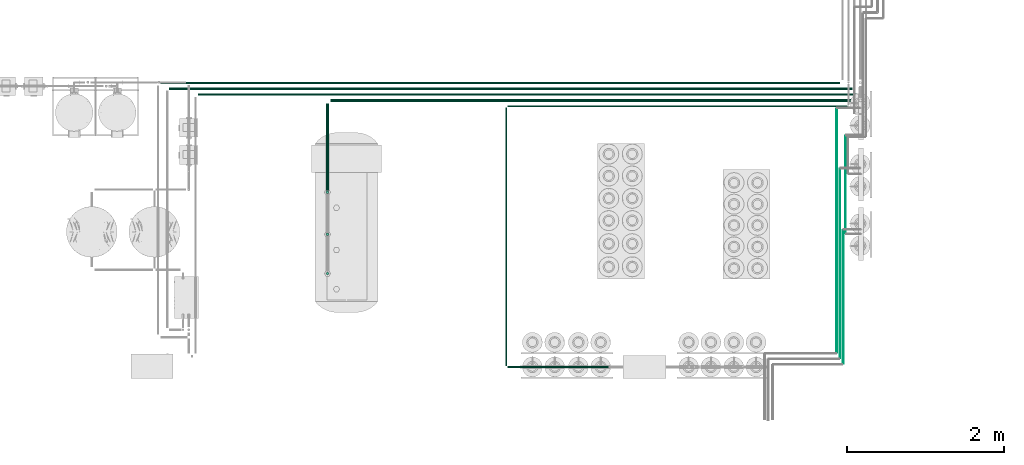
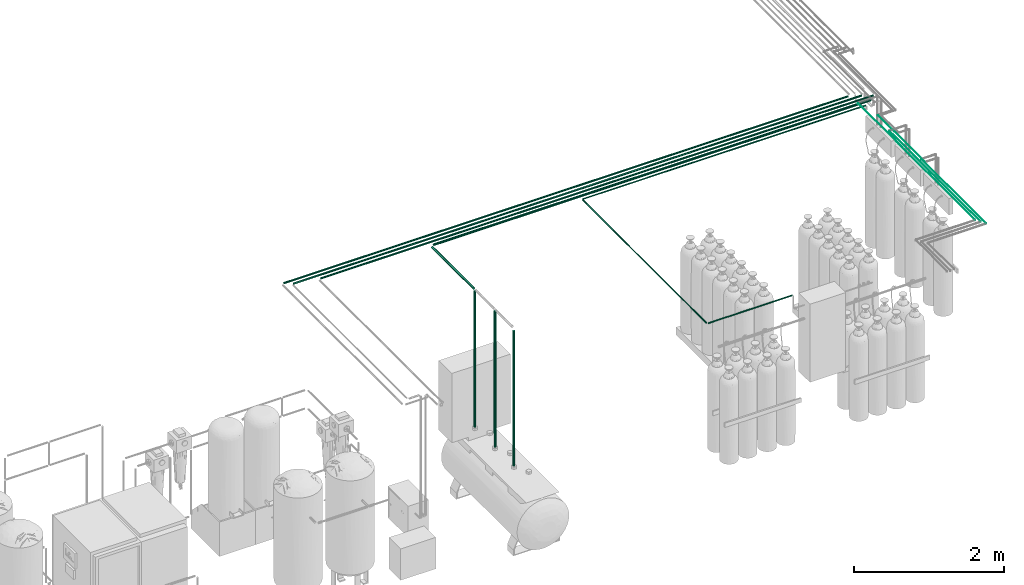
# One storey, part 64 of 331: 15 flow segments.
"""IFC2X3 building model written with IfcOpenShell, lengths in millimetres."""

from ifc_helpers import new_model, entity, si_unit, converted_unit, derived_unit, direction, frame, frame_2d, origin, origin_2d_with_axis, place, context, subcontext, project, spatial, circle, extrude, type_object, element, save


model = new_model("IFC2X3")

# Units and contexts
model_context = context("Model", 3, precision=0.01, world=origin(), true_north=direction((6.12303176911189e-17, 1.0)))
body_context = subcontext(model_context, "Body", "Model", "MODEL_VIEW")
ifc_project = project(units=[si_unit("LENGTHUNIT", "METRE", prefix="MILLI"), si_unit("AREAUNIT", "SQUARE_METRE"), si_unit("VOLUMEUNIT", "CUBIC_METRE"), converted_unit("PLANEANGLEUNIT", "DEGREE", entity("IfcRatioMeasure", 0.0174532925199433), si_unit("PLANEANGLEUNIT", "RADIAN"), dimensions=[0, 0, 0, 0, 0, 0, 0]), si_unit("MASSUNIT", "GRAM", prefix="KILO"), derived_unit("MASSDENSITYUNIT", [(si_unit("MASSUNIT", "GRAM", prefix="KILO"), 1), (si_unit("LENGTHUNIT", "METRE"), -3)]), derived_unit("MOMENTOFINERTIAUNIT", [(si_unit("LENGTHUNIT", "METRE"), 4)]), si_unit("TIMEUNIT", "SECOND"), si_unit("FREQUENCYUNIT", "HERTZ"), si_unit("THERMODYNAMICTEMPERATUREUNIT", "DEGREE_CELSIUS"), derived_unit("THERMALTRANSMITTANCEUNIT", [(si_unit("MASSUNIT", "GRAM", prefix="KILO"), 1), (si_unit("THERMODYNAMICTEMPERATUREUNIT", "KELVIN"), -1), (si_unit("TIMEUNIT", "SECOND"), -3)]), derived_unit("VOLUMETRICFLOWRATEUNIT", [(si_unit("LENGTHUNIT", "METRE"), 3), (si_unit("TIMEUNIT", "SECOND"), -1)]), derived_unit("MASSFLOWRATEUNIT", [(si_unit("MASSUNIT", "GRAM", prefix="KILO"), 1), (si_unit("TIMEUNIT", "SECOND"), -1)]), derived_unit("ROTATIONALFREQUENCYUNIT", [(si_unit("TIMEUNIT", "SECOND"), -1)]), si_unit("ELECTRICCURRENTUNIT", "AMPERE"), si_unit("ELECTRICVOLTAGEUNIT", "VOLT"), si_unit("POWERUNIT", "WATT"), si_unit("FORCEUNIT", "NEWTON", prefix="KILO"), si_unit("ILLUMINANCEUNIT", "LUX"), si_unit("LUMINOUSFLUXUNIT", "LUMEN"), si_unit("LUMINOUSINTENSITYUNIT", "CANDELA"), derived_unit("USERDEFINED", [(si_unit("MASSUNIT", "GRAM", prefix="KILO"), -1), (si_unit("LENGTHUNIT", "METRE"), -2), (si_unit("TIMEUNIT", "SECOND"), 3), (si_unit("LUMINOUSFLUXUNIT", "LUMEN"), 1)]), derived_unit("LINEARVELOCITYUNIT", [(si_unit("LENGTHUNIT", "METRE"), 1), (si_unit("TIMEUNIT", "SECOND"), -1)]), si_unit("PRESSUREUNIT", "PASCAL"), derived_unit("USERDEFINED", [(si_unit("LENGTHUNIT", "METRE"), -2), (si_unit("MASSUNIT", "GRAM", prefix="KILO"), 1), (si_unit("TIMEUNIT", "SECOND"), -2)]), derived_unit("LINEARFORCEUNIT", [(si_unit("MASSUNIT", "GRAM", prefix="KILO"), 1), (si_unit("LENGTHUNIT", "METRE"), 1), (si_unit("TIMEUNIT", "SECOND"), -2), (si_unit("LENGTHUNIT", "METRE"), -1)]), derived_unit("PLANARFORCEUNIT", [(si_unit("MASSUNIT", "GRAM", prefix="KILO"), 1), (si_unit("LENGTHUNIT", "METRE"), 1), (si_unit("TIMEUNIT", "SECOND"), -2), (si_unit("LENGTHUNIT", "METRE"), -2)])], contexts=[model_context])

# Site, building, storey
site_placement = place(None, frame((0.0, -0.00077364408347762, 0.0)))
site = spatial("IfcSite", under=ifc_project, at=site_placement, CompositionType="ELEMENT")
building_placement = place(site_placement, origin())
building = spatial("IfcBuilding", under=site, at=building_placement, CompositionType="ELEMENT")
storey_placement = place(building_placement, origin())
storey = spatial("IfcBuildingStorey", under=building, at=storey_placement, CompositionType="ELEMENT", Elevation=0.0)

# Flow segments
pipe_segment_type = type_object("IfcPipeSegmentType", PredefinedType="NOTDEFINED")
flow_segment_1_placement = place(building_placement, frame((55309.3887764161, -660.725394586212, 2834.40472776408)))
element("IfcFlowSegment", 1, at=flow_segment_1_placement, inside=storey, type_object=pipe_segment_type, context=body_context, shape_type="SweptSolid", body=[
    extrude(circle(Radius=14.0, at=frame_2d((5.41433564649196e-13, 0.0), x_axis=(1.0, 0.0))), frame((0.0, 15.5952722359165, 15.595272235916), z_axis=(1.0, 0.0, 0.0), x_axis=(0.0, 1.0, 0.0)), (0.0, 0.0, 1.0), 8681.61484046799),
])
flow_segment_2_placement = place(building_placement, frame((59743.0035957294, -954.225343218528, 2840.90472948002)))
element("IfcFlowSegment", 2, at=flow_segment_2_placement, inside=storey, type_object=pipe_segment_type, context=body_context, shape_type="SweptSolid", body=[
    extrude(circle(Radius=7.5, at=origin_2d_with_axis()), frame((2.11546496757364e-05, 9.09527223588618, 9.09527223591582), z_axis=(1.0, 2.82061944947099e-06, 0.0), x_axis=(-2.82061944947099e-06, 1.0, 0.0)), (0.0, 0.0, 1.0), 4339.00000001744),
])
flow_segment_3_placement = place(storey_placement, frame((55790.3585349586, -810.725394586227, 2834.40472776406)))
element("IfcFlowSegment", 3, at=flow_segment_3_placement, inside=storey, type_object=pipe_segment_type, context=body_context, shape_type="SweptSolid", body=[
    extrude(circle(Radius=14.0, at=frame_2d((1.35358391162299e-13, 0.0), x_axis=(1.0, 0.0))), frame((0.0, 15.5952722360584, 15.595272235916), z_axis=(1.0, 0.0, 0.0), x_axis=(0.0, -1.0, 0.0)), (0.0, 0.0, 1.0), 8500.64508192548),
])
flow_segment_4_placement = place(storey_placement, frame((59715.9083446482, -4258.23364709027, 2840.90472776408)))
element("IfcFlowSegment", 4, at=flow_segment_4_placement, inside=storey, type_object=pipe_segment_type, context=body_context, shape_type="SweptSolid", body=[
    extrude(circle(Radius=7.5, at=origin_2d_with_axis()), frame((9.09527223591419, 0.0, 9.09527223591582), z_axis=(0.0, 1.0, 0.0), x_axis=(-1.0, 0.0, 0.0)), (0.0, 0.0, 1.0), 3295.10352473999),
])
flow_segment_5_placement = place(storey_placement, frame((59743.0036168841, -4285.32891932618, 2840.90472776408)))
element("IfcFlowSegment", 5, at=flow_segment_5_placement, inside=storey, type_object=pipe_segment_type, context=body_context, shape_type="SweptSolid", body=[
    extrude(circle(Radius=7.5, at=origin_2d_with_axis()), frame((0.0, 9.09527223591528, 9.09527223591582), z_axis=(1.0, 0.0, 0.0), x_axis=(0.0, -1.0, 0.0)), (0.0, 0.0, 1.0), 1290.16209293632),
])
flow_segment_6_placement = place(storey_placement, frame((55419.0036168841, -732.725394586218, 2837.40472776409)))
element("IfcFlowSegment", 6, at=flow_segment_6_placement, inside=storey, type_object=pipe_segment_type, context=body_context, shape_type="SweptSolid", body=[
    extrude(circle(Radius=11.0, at=frame_2d((-4.98118879477261e-11, -5.41433564649196e-13), x_axis=(1.0, 0.0))), frame((0.0, 12.5952722359658, 12.5952722359166), z_axis=(1.0, 0.0, 0.0), x_axis=(0.0, 1.0, 0.0)), (0.0, 0.0, 1.0), 8732.00000000002),
])
flow_segment_7_placement = place(storey_placement, frame((57481.8786168841, -889.225394586222, 2830.90472776409)))
element("IfcFlowSegment", 7, at=flow_segment_7_placement, inside=storey, type_object=pipe_segment_type, context=body_context, shape_type="SweptSolid", body=[
    extrude(circle(Radius=17.5, at=frame_2d((-3.34335226170879e-11, 0.0), x_axis=(1.0, 0.0))), frame((0.0, 19.0952722359494, 19.0952722359157), z_axis=(1.0, 0.0, 0.0), x_axis=(0.0, 1.0, 0.0)), (0.0, 0.0, 1.0), 6728.125),
])
flow_segment_8_placement = place(storey_placement, frame((57422.7833446482, -2022.15280324607, 2830.90472776408)))
element("IfcFlowSegment", 8, at=flow_segment_8_placement, inside=storey, type_object=pipe_segment_type, context=body_context, shape_type="SweptSolid", body=[
    extrude(circle(Radius=17.5, at=frame_2d((-8.66293703438714e-12, 0.0), x_axis=(1.0, 0.0))), frame((19.0952722359119, 0.0, 19.0952722359157), z_axis=(0.0, 1.0, 0.0), x_axis=(-1.0, 0.0, 0.0)), (0.0, 0.0, 1.0), 1112.02268089583),
])
flow_segment_9_placement = place(storey_placement, frame((57422.7833450169, -2062.24807548198, 616.258869116455)))
element("IfcFlowSegment", 9, at=flow_segment_9_placement, inside=storey, type_object=pipe_segment_type, context=body_context, shape_type="SweptSolid", body=[
    extrude(circle(Radius=17.5, at=origin_2d_with_axis()), frame((19.5494740212708, 19.095272235916, 0.00359217367128011), z_axis=(-0.000205267066934748, 0.0, 0.999999978932715), x_axis=(0.999999978932715, 0.0, 0.000205267066934748)), (0.0, 0.0, 1.0), 2212.73758532623),
])
flow_segment_10_placement = place(storey_placement, frame((57422.7833450169, -2600.39161620412, 616.258869116453)))
element("IfcFlowSegment", 10, at=flow_segment_10_placement, inside=storey, type_object=pipe_segment_type, context=body_context, shape_type="SweptSolid", body=[
    extrude(circle(Radius=17.5, at=frame_2d((5.55692398777829e-17, 0.0), x_axis=(1.0, 0.0))), frame((19.5494740212708, 19.0952722359157, 0.00359217367155082), z_axis=(-0.000205267066934748, 0.0, 0.999999978932715), x_axis=(0.999999978932715, 0.0, 0.000205267066934748)), (0.0, 0.0, 1.0), 2212.73758532623),
])
flow_segment_11_placement = place(storey_placement, frame((57422.7914785017, -3101.31984584308, 616.258902887494)))
element("IfcFlowSegment", 11, at=flow_segment_11_placement, inside=storey, type_object=pipe_segment_type, context=body_context, shape_type="SweptSolid", body=[
    extrude(circle(Radius=17.5, at=frame_2d((2.75234088567917e-17, 0.0), x_axis=(1.0, 0.0))), frame((19.5413405364134, 19.0952722359157, 0.00355840262940141), z_axis=(-0.00020333729309615, 0.0, 0.999999979326972), x_axis=(0.999999979326972, 0.0, 0.00020333729309615)), (0.0, 0.0, 1.0), 2193.737584888),
])
flow_segment_12_placement = place(storey_placement, frame((64054.4083446482, -2566.0, 2919.40472776408)))
element("IfcFlowSegment", 12, at=flow_segment_12_placement, inside=storey, type_object=pipe_segment_type, context=body_context, shape_type="SweptSolid", body=[
    extrude(circle(Radius=4.0, at=origin_2d_with_axis()), frame((5.59527223591499, 0.0, 5.59527223591607), z_axis=(0.0, 1.0, 0.0), x_axis=(-1.0, 0.0, 0.0)), (0.0, 0.0, 1.0), 1242.00000000001),
])
flow_segment_13_placement = place(storey_placement, frame((63944.2054272045, -4095.57213879895, 2941.90472776408)))
element("IfcFlowSegment", 13, at=flow_segment_13_placement, inside=storey, type_object=pipe_segment_type, context=body_context, shape_type="SweptSolid", body=[
    extrude(circle(Radius=4.0, at=frame_2d((2.59888111031614e-10, 0.0), x_axis=(1.0, 0.0))), frame((5.59527223617488, 0.0, 5.59527223591607), z_axis=(0.0, 1.0, 0.0), x_axis=(-1.0, 0.0, 0.0)), (0.0, 0.0, 1.0), 3122.00000000001),
])
flow_segment_14_placement = place(storey_placement, frame((63984.2054272044, -4166.65453787738, 2941.90472776408)))
element("IfcFlowSegment", 14, at=flow_segment_14_placement, inside=storey, type_object=pipe_segment_type, context=body_context, shape_type="SweptSolid", body=[
    extrude(circle(Radius=4.0, at=origin_2d_with_axis()), frame((5.59527223591499, 0.0, 5.59527223591607), z_axis=(0.0, 1.0, 0.0), x_axis=(-1.0, 0.0, 0.0)), (0.0, 0.0, 1.0), 2422.00000000001),
])
flow_segment_15_placement = place(storey_placement, frame((64026.9379752767, -4237.23364709028, 2941.90472776408)))
element("IfcFlowSegment", 15, at=flow_segment_15_placement, inside=storey, type_object=pipe_segment_type, context=body_context, shape_type="SweptSolid", body=[
    extrude(circle(Radius=4.0, at=frame_2d((8.66293703438714e-12, 0.0), x_axis=(1.0, 0.0))), frame((5.59527223592365, 0.0, 5.59527223591607), z_axis=(0.0, 1.0, 0.0), x_axis=(-1.0, 0.0, 0.0)), (0.0, 0.0, 1.0), 1710.64085896952),
])

save(model, "model.ifc")
